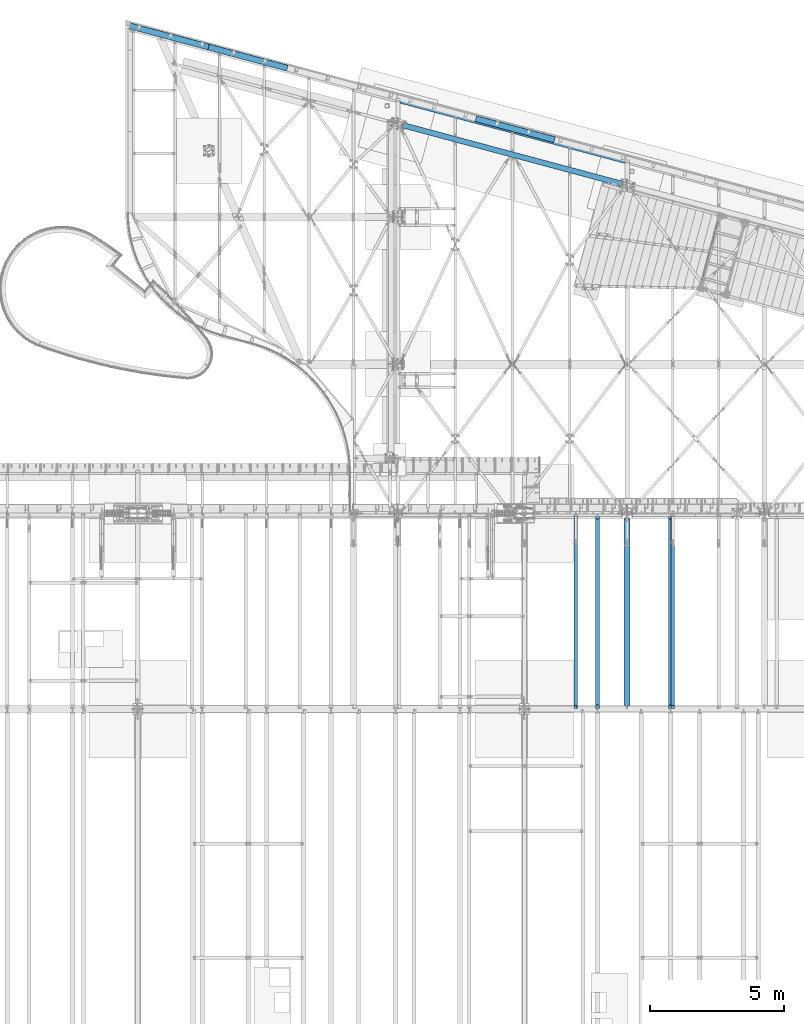
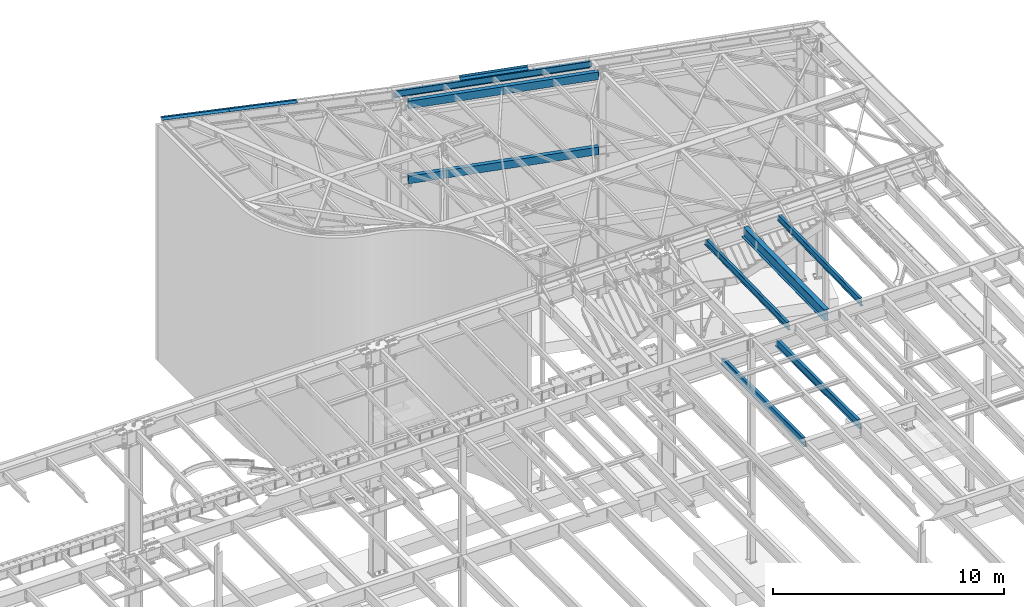
# One storey, part 1160 of 1763: 11 beams, 9 elements without a shape of their own.
"""IFC2X3 building model written with IfcOpenShell, lengths in millimetres."""

from ifc_helpers import new_model, si_unit, frame, origin_with_axes, place, context, subcontext, project, spatial, faceted_brep, material, type_object, element, aggregate, save


model = new_model("IFC2X3")

# Units and contexts
model_context = context("Model", 3, precision=1e-05, world=origin_with_axes())
body_context = subcontext(model_context, "Body", "Model", "MODEL_VIEW")
ifc_project = project(units=[si_unit("LENGTHUNIT", "METRE", prefix="MILLI"), si_unit("AREAUNIT", "SQUARE_METRE"), si_unit("VOLUMEUNIT", "CUBIC_METRE"), si_unit("MASSUNIT", "GRAM", prefix="KILO"), si_unit("TIMEUNIT", "SECOND"), si_unit("PLANEANGLEUNIT", "RADIAN"), si_unit("SOLIDANGLEUNIT", "STERADIAN"), si_unit("THERMODYNAMICTEMPERATUREUNIT", "DEGREE_CELSIUS"), si_unit("LUMINOUSINTENSITYUNIT", "LUMEN")], contexts=[model_context])

# Site, building, storey
site_placement = place(None, origin_with_axes())
site = spatial("IfcSite", under=ifc_project, at=site_placement, CompositionType="ELEMENT")
building_placement = place(site_placement, origin_with_axes())
building = spatial("IfcBuilding", under=site, at=building_placement, Name="Undefined", CompositionType="ELEMENT")
storey_placement = place(building_placement, origin_with_axes())
storey = spatial("IfcBuildingStorey", under=building, at=storey_placement, Name="Undefined", CompositionType="ELEMENT", Elevation=0.0)

# Assembly, beam
assembly_1_placement = place(storey_placement, origin_with_axes())
assembly_1 = element("IfcElementAssembly", 1, at=assembly_1_placement, inside=storey, Name="BEAM", AssemblyPlace="NOTDEFINED", PredefinedType="RIGID_FRAME")
ifc_material_1 = material()
beam_type_1 = type_object("IfcBeamType", Name="HSS16X8X5/8", PredefinedType="NOTDEFINED")
beam_1_placement = place(assembly_1_placement, frame((-39672.2896174488, 66681.4025701184, 8280.4), z_axis=(0.0, 0.0, 1.0), x_axis=(0.965925826295336, -0.25881904507913, 0.0)))
beam_1 = element("IfcBeam", 2, at=beam_1_placement, type_object=beam_type_1, material=ifc_material_1, Name="BEAM", ObjectType="HSS16X8X5/8", context=body_context, shape_type="Brep", body=[
    faceted_brep([(174.629929660281, 101.600000000712, 203.2), (174.629929640418, 101.600000000726, -203.2), (158.754929640003, 85.7250000006388, -187.325), (158.754929640003, 85.7250000006388, 187.325), (174.629929639552, -101.599999999729, -203.2), (158.754929640003, -85.7249999997366, -187.325), (174.629929646464, -101.600000007791, 203.200000005744), (158.754929640003, -85.7249999997366, 187.325), (8704.59949159464, -85.7249999754858, -187.325), (8688.72449160701, -101.599999975559, -203.2), (8688.7244915844, 101.600000024882, -203.2), (8704.59949159464, 85.7250000248896, -187.325), (8704.59949160298, -85.7249999917767, 187.324999992047), (8688.72449157427, -101.599999975573, 203.2), (8704.59949159464, 85.7250000248896, 187.325), (8688.72449157427, 101.600000024882, 203.2)], [[[0, 1, 2, 3]], [[4, 5, 2, 1]], [[6, 7, 5, 4]], [[8, 9, 10, 11]], [[12, 13, 9, 8]], [[14, 15, 13, 12]], [[13, 15, 0, 6]], [[9, 13, 6, 4]], [[10, 9, 4, 1]], [[15, 10, 1, 0]], [[14, 11, 10, 15]], [[11, 14, 3, 2]], [[8, 11, 2, 5]], [[12, 8, 5, 7]], [[14, 12, 7, 3]], [[0, 3, 7, 6]]]),
])
aggregate(assembly_1, [beam_1])

assembly_2_placement = place(storey_placement, origin_with_axes())
assembly_2 = element("IfcElementAssembly", 3, at=assembly_2_placement, inside=storey, Name="BEAM", AssemblyPlace="NOTDEFINED", PredefinedType="RIGID_FRAME")
beam_2_placement = place(assembly_2_placement, frame((-39672.2896174487, 66681.4025701184, 12242.8), z_axis=(0.0, 0.0, 1.0), x_axis=(0.965925826295336, -0.25881904507913, 0.0)))
beam_2 = element("IfcBeam", 4, at=beam_2_placement, type_object=beam_type_1, material=ifc_material_1, Name="BEAM", ObjectType="HSS16X8X5/8", context=body_context, shape_type="Brep", body=[
    faceted_brep([(174.629929660281, 101.600000000712, 203.2), (174.629929640418, 101.600000000726, -203.2), (158.754929640003, 85.7250000006388, -187.325), (158.754929640003, 85.7250000006388, 187.325), (174.629929639552, -101.599999999729, -203.2), (158.754929640003, -85.7249999997366, -187.325), (174.629929646464, -101.600000007791, 203.200000005744), (158.754929640003, -85.7249999997366, 187.325), (8704.71665785171, -85.7249999754931, -187.325000000001), (8688.84165768397, -101.59999997558, -203.200000000001), (8688.84165766144, 101.600000024868, -203.200000000001), (8704.71665785171, 85.7250000248823, -187.325000000001), (8704.71665774003, -85.7249999317428, 187.324999932076), (8688.84165783197, -101.59999997558, 203.200000000001), (8704.71665785171, 85.7250000248823, 187.325000000001), (8688.84165783197, 101.600000024868, 203.200000000001)], [[[0, 1, 2, 3]], [[4, 5, 2, 1]], [[6, 7, 5, 4]], [[8, 9, 10, 11]], [[12, 13, 9, 8]], [[14, 15, 13, 12]], [[13, 15, 0, 6]], [[9, 13, 6, 4]], [[10, 9, 4, 1]], [[15, 10, 1, 0]], [[14, 11, 10, 15]], [[11, 14, 3, 2]], [[8, 11, 2, 5]], [[12, 8, 5, 7]], [[14, 12, 7, 3]], [[0, 3, 7, 6]]]),
])
aggregate(assembly_2, [beam_2])

# Assembly, beams
assembly_3_placement = place(storey_placement, origin_with_axes())
assembly_3 = element("IfcElementAssembly", 5, at=assembly_3_placement, inside=storey, Name="BEAM", AssemblyPlace="NOTDEFINED", PredefinedType="RIGID_FRAME")
ifc_material_2 = material(Name="STEEL/A36")
beam_type_2 = type_object("IfcBeamType", PredefinedType="NOTDEFINED")
beam_3_placement = place(assembly_3_placement, frame((-48255.4900932477, 69842.5533379744, 12710.7144148035), z_axis=(-0.965507252027915, 0.25870688944179, 0.0294362300041612), x_axis=(0.258819045079128, 0.965925826295336, 0.0)))
beam_3 = element("IfcBeam", 6, at=beam_3_placement, type_object=beam_type_2, material=ifc_material_2, Name="BENT_PLATE", context=body_context, shape_type="Brep", body=[
    faceted_brep([(0.0, -3.17499999999927, -1523.99999999999), (0.0, -3.17499999999927, 1524.0), (0.0, 3.17499999999927, 1524.0), (0.0, 3.17499999999927, -1523.99999999999), (228.599995165183, 3.17499993969795, 1523.99999998704), (228.599994834185, 3.17499994154787, -1524.00000000063), (222.249995293445, -3.17500005680085, -1524.00000000046), (222.249995624443, -3.17500005865077, 1523.99999998722), (228.600000545521, -73.0249989343301, 1523.99999998058), (228.600000477083, -73.0249986697763, -1524.00000000709), (222.250000545486, -73.0249993936013, 1523.99999998076), (222.250000477034, -73.0249991290493, -1524.0000000069)], [[[0, 1, 2, 3]], [[3, 2, 4, 5]], [[1, 0, 6, 7]], [[5, 4, 8, 9]], [[4, 2, 1, 7, 10, 8]], [[7, 6, 11, 10]], [[6, 0, 3, 5, 9, 11]], [[10, 11, 9, 8]]]),
])
beam_4_placement = place(assembly_3_placement, frame((-45312.6239887956, 69054.0147402431, 12620.9927843504), z_axis=(-0.965507252027915, 0.25870688944179, 0.0294362300041612), x_axis=(0.258819045079128, 0.965925826295336, 0.0)))
beam_4 = element("IfcBeam", 7, at=beam_4_placement, type_object=beam_type_2, material=ifc_material_2, Name="BENT_PLATE", context=body_context, shape_type="Brep", body=[
    faceted_brep([(0.0, -3.17499999999927, -1523.99999999999), (0.0, -3.17499999999927, 1524.0), (0.0, 3.17499999999927, 1524.0), (0.0, 3.17499999999927, -1523.99999999999), (228.599995165183, 3.17499993969795, 1523.99999998704), (228.599994834185, 3.17499994154787, -1524.00000000063), (222.249995293445, -3.17500005680085, -1524.00000000046), (222.249995624443, -3.17500005865077, 1523.99999998722), (228.600000545521, -73.0249989343301, 1523.99999998058), (228.600000477083, -73.0249986697763, -1524.00000000709), (222.250000545486, -73.0249993936013, 1523.99999998076), (222.250000477034, -73.0249991290493, -1524.0000000069)], [[[0, 1, 2, 3]], [[3, 2, 4, 5]], [[1, 0, 6, 7]], [[5, 4, 8, 9]], [[4, 2, 1, 7, 10, 8]], [[7, 6, 11, 10]], [[6, 0, 3, 5, 9, 11]], [[10, 11, 9, 8]]]),
])
aggregate(assembly_3, [beam_3, beam_4])

# Assembly, beam
assembly_4_placement = place(storey_placement, origin_with_axes())
assembly_4 = element("IfcElementAssembly", 8, at=assembly_4_placement, inside=storey, Name="BEAM", AssemblyPlace="NOTDEFINED", PredefinedType="RIGID_FRAME")
ifc_material_3 = material(Name="STEEL/A992")
beam_type_3 = type_object("IfcBeamType", Name="W14X22", PredefinedType="NOTDEFINED")
beam_5_placement = place(assembly_4_placement, frame((-39677.0521174484, 67543.9678106676, 12271.375), z_axis=(0.0, 0.0, 1.0), x_axis=(0.965925826295336, -0.25881904507913, 0.0)))
beam_5 = element("IfcBeam", 9, at=beam_5_placement, type_object=beam_type_3, material=ifc_material_3, Name="BEAM", ObjectType="W14X22", context=body_context, shape_type="Brep", body=[
    faceted_brep([(8785.09744253859, -63.4999999752108, 174.625), (8785.09744253859, -63.4999999752108, 166.6875), (8768.93340750672, -3.17499997511914, 166.6875), (8768.93340750672, -3.17499997511914, 152.399999844461), (8767.23193013496, 3.17500002488669, 152.399999844461), (8767.23193013496, 3.17500002488669, 166.6875), (8751.06789510309, 63.5000000249784, 166.6875), (8751.06789510309, 63.5000000249784, 174.625), (8769.93423996848, -3.17499997511186, 147.539920326411), (8768.23276259669, 3.17500002489396, 147.539920326411), (8772.78436968398, -3.17499997511186, 143.419743858254), (8771.0828923122, 3.17500002489396, 143.419743858254), (8777.04989024053, -3.17499997509003, 140.666729957778), (8775.34841286876, 3.17500002491579, 140.666729957778), (8782.08141480046, -3.17499997508276, 139.700000035196), (8780.37993742868, 3.17500002493034, 139.700000035196), (8852.69398206195, -3.17499997487903, 139.700000035311), (8852.69398206194, 3.17500002513407, 139.700000035315), (113.981326006629, -63.4999999998181, 174.625), (79.9517785711287, 63.5000000003711, 174.625), (79.9517785711287, 63.5000000003711, 166.6875), (96.1158136029917, 3.17500000028667, 166.6875), (96.1158136029917, 3.17500000028667, 150.812499809434), (97.8172909747736, -3.17499999971915, 150.812499809434), (97.8172909747736, -3.17499999971915, 166.6875), (113.981326006629, -63.4999999998181, 166.6875), (95.1149811412397, 3.1750000002794, 145.952420291384), (96.8164585130216, -3.17499999972642, 145.952420291384), (92.2648514257526, 3.17500000026484, 141.832243823226), (93.96632879752, -3.17499999974098, 141.832243823226), (87.9993308691919, 3.17500000025029, 139.079229922751), (89.7008082409666, -3.17499999975553, 139.079229922751), (82.9678063092651, 3.17500000023574, 138.112500000168), (84.6692836810398, -3.17499999977008, 138.112500000168), (23.0380015252667, 3.17500000006839, 138.112500000267), (23.0380015252958, -3.1749999999447, 138.11250000027), (5.17248912165087, 63.5000000001601, -166.6875), (5.17248912165087, 63.5000000001601, -174.625), (21.3365241535139, 3.17500000007567, -174.625), (21.3365241535139, 3.17500000006112, -166.6875), (8751.06789520969, 63.5000000249784, -166.6875), (8751.06789520969, 63.5000000249784, -174.625), (39.2020365571589, -63.5000000000291, -174.625), (23.0380015252886, -3.17499999993015, -174.625), (23.0380015252667, 3.17500000008295, -174.625), (8785.09744264519, -63.4999999752035, -174.625), (39.2020365571589, -63.5000000000291, -166.6875), (8785.09744264519, -63.4999999752035, -166.6875), (23.0380015252958, -3.1749999999447, -166.6875), (8768.93340761332, -3.17499997511914, -166.6875), (23.0380015252667, 3.17500000006839, -166.6875), (8767.23193024155, 3.17500002488669, -166.6875), (8767.23193024155, 3.17500002488669, -155.574999789502), (8768.93340761332, -3.17499997511914, -155.574999789502), (8768.23276270329, 3.17500002488669, -150.714920271452), (8769.93424007506, -3.17499997511914, -150.714920271452), (8771.0828924188, 3.17500002490124, -146.594743803294), (8772.78436979057, -3.17499997510458, -146.594743803294), (8775.34841297536, 3.17500002490851, -143.841729902819), (8777.04989034712, -3.17499997509731, -143.841729902819), (8780.37993753528, 3.17500002493034, -142.874999980237), (8782.08141490705, -3.17499997508276, -142.874999980237), (8852.69398206195, -3.17499997487903, -142.874999980353), (8852.69398206194, 3.17500002513407, -142.874999980357)], [[[0, 1, 2, 3, 4, 5, 6, 7]], [[8, 9, 4, 3]], [[10, 11, 9, 8]], [[12, 13, 11, 10]], [[14, 15, 13, 12]], [[16, 17, 15, 14]], [[18, 19, 20, 21, 22, 23, 24, 25]], [[23, 22, 26, 27]], [[27, 26, 28, 29]], [[29, 28, 30, 31]], [[31, 30, 32, 33]], [[33, 32, 34, 35]], [[36, 37, 38, 39]], [[37, 36, 40, 41]], [[42, 43, 44, 38, 37, 41, 45]], [[46, 42, 45, 47]], [[48, 46, 47, 49]], [[42, 46, 48, 43]], [[35, 34, 50, 44, 43, 48]], [[39, 38, 44, 50]], [[36, 39, 50, 51, 40]], [[47, 45, 41, 40, 51, 52, 53, 49]], [[53, 52, 54, 55]], [[55, 54, 56, 57]], [[57, 56, 58, 59]], [[59, 58, 60, 61]], [[62, 61, 60, 63]], [[12, 10, 8, 3, 2, 24, 23, 27, 29, 31, 33, 35, 48, 49, 53, 55, 57, 59, 61, 62, 16, 14]], [[25, 24, 2, 1]], [[18, 25, 1, 0]], [[19, 18, 0, 7]], [[20, 19, 7, 6]], [[21, 20, 6, 5]], [[63, 60, 58, 56, 54, 52, 51, 50, 34, 32, 30, 28, 26, 22, 21, 5, 4, 9, 11, 13, 15, 17]], [[62, 63, 17, 16]]]),
])

assembly_5_placement = place(storey_placement, origin_with_axes())
assembly_5 = element("IfcElementAssembly", 10, at=assembly_5_placement, inside=storey, Name="BEAM", AssemblyPlace="NOTDEFINED", PredefinedType="RIGID_FRAME")
beam_6_placement = place(assembly_5_placement, frame((-29398.4096174484, 44809.2121579122, 11421.5633921212), z_axis=(0.0, -0.0206852279954837, 0.999786037781472), x_axis=(0.0, 0.999786037781472, 0.0206852279954825)))
beam_6 = element("IfcBeam", 11, at=beam_6_placement, type_object=beam_type_3, material=ifc_material_3, Name="BEAM", ObjectType="W14X22", context=body_context, shape_type="Brep", body=[
    faceted_brep([(116.24722620719, -3.17499999999927, 136.265001678286), (116.24722620719, 3.17499999999927, 136.265001678286), (17.4665018602245, 3.17499999999927, 136.265001678306), (17.4665018602245, -3.17499999999927, 136.265001678306), (121.10730572528, -3.17499999999927, 137.231731600872), (121.10730572528, 3.17499999999927, 137.231731600872), (125.227482193462, -3.17499999999927, 139.984745501344), (125.227482193462, 3.17499999999927, 139.984745501344), (127.980496093973, -3.17499999999927, 144.104921969487), (127.980496093973, 3.17499999999927, 144.104921969487), (128.947226016564, -3.17499999999927, 148.965001487522), (128.947226016564, 3.17499999999927, 148.965001487522), (128.947226016564, -63.5, 174.624999999836), (128.947226016564, 63.5, 174.624999999836), (128.947226016571, 63.5, 166.687499999842), (128.947226016571, 3.17499999999927, 166.687499999842), (128.947226016571, -3.17499999999927, 166.687499999842), (128.947226016571, -63.5, 166.687499999842), (11.1985191797066, -3.17499999999927, -166.687499999876), (11.1985191797066, -63.5, -166.687499999876), (7286.68019766203, -63.5, -166.687500001812), (7286.68019766203, -3.17499999999927, -166.687500001812), (11.0342950447375, -63.5, -174.624999999869), (7286.51597352705, -63.5, -174.625000001804), (11.0342950447375, 63.5, -174.624999999869), (7286.51597352705, 63.5, -174.625000001804), (11.1985191797066, 63.5, -166.687499999876), (7286.68019766203, 63.5, -166.687500001812), (11.1985191797066, 3.17499999999927, -166.687499999876), (7286.68019766203, 3.17499999999927, -166.687500001812), (7292.55404233934, 3.17499999999927, 117.214997851617), (7292.55404233934, -3.17499999999927, 117.214997851617), (7175.8289043449, 3.17499999999927, 117.214997851641), (7175.8289043449, -3.17499999999927, 117.214997851641), (7170.96882482681, 3.17499999999927, 118.181727774227), (7170.96882482681, -3.17499999999927, 118.181727774227), (7166.84864835862, 3.17499999999927, 120.9347416747), (7166.84864835862, -3.17499999999927, 120.9347416747), (7164.09563445811, 3.17499999999927, 125.054918142847), (7164.09563445811, -3.17499999999927, 125.054918142847), (7163.12890453552, 3.17499999999927, 129.914997660881), (7163.12890453552, -3.17499999999927, 129.914997660881), (7163.12890453552, -63.5, 174.624999997965), (7163.12890453552, -63.5, 166.687499997972), (7163.12890453552, -3.17499999999927, 166.687499997972), (7163.12890453552, 3.17499999999927, 166.687499997972), (7163.12890453552, 63.5, 166.687499997972), (7163.12890453552, 63.5, 174.624999997965)], [[[0, 1, 2, 3]], [[4, 5, 1, 0]], [[6, 7, 5, 4]], [[8, 9, 7, 6]], [[10, 11, 9, 8]], [[12, 13, 14, 15, 11, 10, 16, 17]], [[18, 19, 20, 21]], [[19, 22, 23, 20]], [[22, 24, 25, 23]], [[24, 26, 27, 25]], [[26, 28, 29, 27]], [[21, 20, 23, 25, 27, 29, 30, 31]], [[31, 30, 32, 33]], [[33, 32, 34, 35]], [[35, 34, 36, 37]], [[37, 36, 38, 39]], [[39, 38, 40, 41]], [[42, 43, 44, 41, 40, 45, 46, 47]], [[43, 42, 12, 17]], [[44, 43, 17, 16]], [[8, 6, 4, 0, 3, 18, 21, 31, 33, 35, 37, 39, 41, 44, 16, 10]], [[28, 26, 24, 22, 19, 18, 3, 2]], [[45, 40, 38, 36, 34, 32, 30, 29, 28, 2, 1, 5, 7, 9, 11, 15]], [[46, 45, 15, 14]], [[47, 46, 14, 13]], [[42, 47, 13, 12]]]),
])
aggregate(assembly_5, [beam_6])

assembly_6_placement = place(storey_placement, origin_with_axes())
assembly_6 = element("IfcElementAssembly", 12, at=assembly_6_placement, inside=storey, Name="BEAM", AssemblyPlace="NOTDEFINED", PredefinedType="RIGID_FRAME")
beam_7_placement = place(assembly_6_placement, frame((-33032.1372736984, 44809.2121579121, 11421.5633921212), z_axis=(0.0, -0.0206852279954837, 0.999786037781472), x_axis=(0.0, 0.999786037781472, 0.0206852279954825)))
beam_7 = element("IfcBeam", 13, at=beam_7_placement, type_object=beam_type_3, material=ifc_material_3, Name="BEAM", ObjectType="W14X22", context=body_context, shape_type="Brep", body=[
    faceted_brep([(116.24722620719, -3.17499999999927, 136.265001678286), (116.24722620719, 3.17499999999927, 136.265001678286), (17.4665018602245, 3.17499999999927, 136.265001678306), (17.4665018602245, -3.17499999999927, 136.265001678306), (121.10730572528, -3.17499999999927, 137.231731600872), (121.10730572528, 3.17499999999927, 137.231731600872), (125.227482193462, -3.17499999999927, 139.984745501344), (125.227482193462, 3.17499999999927, 139.984745501344), (127.980496093973, -3.17499999999927, 144.104921969487), (127.980496093973, 3.17499999999927, 144.104921969487), (128.947226016564, -3.17499999999927, 148.965001487522), (128.947226016564, 3.17499999999927, 148.965001487522), (128.947226016564, -63.5, 174.624999999836), (128.947226016564, 63.5, 174.624999999836), (128.947226016571, 63.5, 166.687499999842), (128.947226016571, 3.17499999999927, 166.687499999842), (128.947226016571, -3.17499999999927, 166.687499999842), (128.947226016571, -63.5, 166.687499999842), (11.1985191797066, -3.17499999999927, -166.687499999876), (11.1985191797066, -63.5, -166.687499999876), (7286.68019766203, -63.5, -166.687500001812), (7286.68019766203, -3.17499999999927, -166.687500001812), (11.0342950447375, -63.5, -174.624999999869), (7286.51597352705, -63.5, -174.625000001804), (11.0342950447375, 63.5, -174.624999999869), (7286.51597352705, 63.5, -174.625000001804), (11.1985191797066, 63.5, -166.687499999876), (7286.68019766203, 63.5, -166.687500001812), (11.1985191797066, 3.17499999999927, -166.687499999876), (7286.68019766203, 3.17499999999927, -166.687500001812), (7292.02852510755, 3.17499999999927, 91.8149978515976), (7292.02852510755, -3.17499999999927, 91.8149978515976), (7125.028904344, 3.17499999999927, 91.8149978516285), (7125.028904344, -3.17499999999927, 91.8149978516285), (7120.16882482591, 3.17499999999927, 92.7817277742161), (7120.16882482591, -3.17499999999927, 92.7817277742161), (7116.04864835773, 3.17499999999927, 95.5347416746881), (7116.04864835773, -3.17499999999927, 95.5347416746881), (7113.29563445722, 3.17499999999927, 99.6549181428345), (7113.29563445722, -3.17499999999927, 99.6549181428345), (7112.32890453462, 3.17499999999927, 104.51499766087), (7112.32890453462, -3.17499999999927, 104.51499766087), (7112.32890453463, -63.5, 174.624999997979), (7112.32890453462, -63.5, 166.687499997985), (7112.32890453462, -3.17499999999927, 166.687499997985), (7112.32890453462, 3.17499999999927, 166.687499997985), (7112.32890453462, 63.5, 166.687499997985), (7112.32890453463, 63.5, 174.624999997979)], [[[0, 1, 2, 3]], [[4, 5, 1, 0]], [[6, 7, 5, 4]], [[8, 9, 7, 6]], [[10, 11, 9, 8]], [[12, 13, 14, 15, 11, 10, 16, 17]], [[18, 19, 20, 21]], [[19, 22, 23, 20]], [[22, 24, 25, 23]], [[24, 26, 27, 25]], [[26, 28, 29, 27]], [[21, 20, 23, 25, 27, 29, 30, 31]], [[31, 30, 32, 33]], [[33, 32, 34, 35]], [[35, 34, 36, 37]], [[37, 36, 38, 39]], [[39, 38, 40, 41]], [[42, 43, 44, 41, 40, 45, 46, 47]], [[43, 42, 12, 17]], [[44, 43, 17, 16]], [[8, 6, 4, 0, 3, 18, 21, 31, 33, 35, 37, 39, 41, 44, 16, 10]], [[28, 26, 24, 22, 19, 18, 3, 2]], [[45, 40, 38, 36, 34, 32, 30, 29, 28, 2, 1, 5, 7, 9, 11, 15]], [[46, 45, 15, 14]], [[47, 46, 14, 13]], [[42, 47, 13, 12]]]),
])
aggregate(assembly_6, [beam_7])

# Beam
beam_type_4 = type_object("IfcBeamType", PredefinedType="NOTDEFINED")
beam_8_placement = place(assembly_4_placement, frame((-35323.3129177373, 66377.3869081666, 12449.175), z_axis=(-0.965925827679309, 0.258819039914073, 0.0), x_axis=(0.258819045079128, 0.965925826295336, 0.0)))
beam_8 = element("IfcBeam", 14, at=beam_8_placement, type_object=beam_type_4, material=ifc_material_2, Name="BENT_PLATE", context=body_context, shape_type="Brep", body=[
    faceted_brep([(0.0, -3.17499999999927, -1523.99999999999), (0.0, -3.17499999999927, 1524.0), (0.0, 3.17499999999927, 1524.0), (0.0, 3.17499999999927, -1523.99999999999), (228.599995165183, 3.17499993969795, 1523.99999998704), (228.599994834185, 3.17499994154787, -1524.00000000063), (222.249995293445, -3.17500005680085, -1524.00000000046), (222.249995624443, -3.17500005865077, 1523.99999998722), (228.599994977769, -123.824999999819, 1524.000000004), (228.599994986405, -123.824999999819, -1524.00000000269), (222.249994977741, -123.824999999819, 1524.00000000397), (222.249994986378, -123.824999999819, -1524.00000000271)], [[[0, 1, 2, 3]], [[3, 2, 4, 5]], [[1, 0, 6, 7]], [[5, 4, 8, 9]], [[4, 2, 1, 7, 10, 8]], [[7, 6, 11, 10]], [[6, 0, 3, 5, 9, 11]], [[10, 11, 9, 8]]]),
])

aggregate(assembly_4, [beam_8, beam_5])

# Assembly, beam
assembly_7_placement = place(storey_placement, origin_with_axes())
assembly_7 = element("IfcElementAssembly", 15, at=assembly_7_placement, inside=storey, Name="BEAM", AssemblyPlace="NOTDEFINED", PredefinedType="RIGID_FRAME")
beam_type_5 = type_object("IfcBeamType", Name="W24X76", PredefinedType="NOTDEFINED")
beam_9_placement = place(assembly_7_placement, frame((-31109.3096174484, 44811.8720196671, 11293.0034049879), z_axis=(0.0, -0.0206852279954837, 0.999786037781472), x_axis=(0.0, 0.999786037781472, 0.0206852279954825)))
beam_9 = element("IfcBeam", 16, at=beam_9_placement, type_object=beam_type_5, material=ifc_material_3, Name="BEAM", ObjectType="W24X76", context=body_context, shape_type="Brep", body=[
    faceted_brep([(6.49632960907184, -5.55625000000146, -265.372499999168), (6.49632960907184, 5.55625000000146, -265.372499999168), (113.586795220392, 5.55625000000146, -265.372499999228), (113.586795220392, -5.55625000000146, -265.372499999228), (118.446874738482, 5.55625000000146, -266.339229921816), (118.446874738482, -5.55625000000146, -266.339229921816), (122.567051206664, 5.55625000000146, -269.092243822288), (122.567051206664, -5.55625000000146, -269.092243822288), (125.32006510716, 5.55625000000146, -273.212420290434), (125.32006510716, -5.55625000000146, -273.212420290434), (126.286795029759, -5.55625000000146, -278.07249980847), (126.286795029759, 5.55625000000146, -278.07249980847), (126.286795029759, 5.55625000000146, -285.749999999816), (126.286795029759, 114.299999999999, -285.749999999816), (126.286795029751, 114.299999999999, -303.212499999803), (126.286795029751, -114.299999999999, -303.212499999803), (126.286795029759, -114.299999999999, -285.749999999816), (126.286795029759, -5.55625000000146, -285.749999999816), (126.286795029817, 5.55625000000146, 285.749999999754), (126.286795029817, 114.299999999999, 285.749999999754), (7109.66847354787, 114.299999999999, 285.749999997897), (7109.66847354787, 5.55625000000146, 285.749999997897), (113.58679522045, -5.55625000000146, 264.852501677899), (113.58679522045, 5.55625000000146, 264.852501677899), (17.4665018600936, 5.55625000000146, 264.852501677915), (17.4665018600936, -5.55625000000146, 264.852501677915), (118.446874738533, -5.55625000000146, 265.819231600481), (118.446874738533, 5.55625000000146, 265.819231600481), (122.567051206723, -5.55625000000146, 268.572245500953), (122.567051206723, 5.55625000000146, 268.572245500953), (125.320065107226, -5.55625000000146, 272.692421969095), (125.320065107226, 5.55625000000146, 272.692421969095), (126.286795029824, -5.55625000000146, 277.552501487131), (126.286795029824, 5.55625000000146, 277.552501487131), (126.286795029817, -114.299999999999, 303.212499999741), (126.286795029817, 114.299999999999, 303.212499999741), (126.286795029817, -5.55625000000146, 285.749999999754), (126.286795029817, -114.299999999999, 285.749999999754), (7109.66847354787, -5.55625000000146, 285.749999997897), (7109.66847354787, -114.299999999999, 285.749999997897), (7109.66847354788, -114.299999999999, 303.212499997884), (7109.66847354788, 114.299999999999, 303.212499997884), (7109.66847354787, -5.55625000000146, 233.102497660489), (7109.66847354787, 5.55625000000146, 233.102497660489), (7110.63520347048, -5.55625000000146, 228.242418142454), (7110.63520347048, 5.55625000000146, 228.242418142454), (7113.38821737097, -5.55625000000146, 224.122241674309), (7113.38821737097, 5.55625000000146, 224.122241674309), (7117.50839383915, -5.55625000000146, 221.369227773837), (7117.50839383915, 5.55625000000146, 221.369227773837), (7122.36847335724, -5.55625000000146, 220.402497851248), (7122.36847335724, 5.55625000000146, 220.402497851248), (7292.02852510743, -5.55625000000146, 220.402497851217), (7292.02852510743, 5.55625000000146, 220.402497851217), (7281.55640465069, -5.55625000000146, -285.750000001717), (7281.55640465069, -114.299999999999, -285.750000001717), (7281.19511155374, -114.299999999999, -303.212500001704), (7281.19511155374, 114.299999999999, -303.212500001704), (7281.55640465069, 114.299999999999, -285.750000001717), (7281.55640465069, 5.55625000000146, -285.750000001717)], [[[0, 1, 2, 3]], [[3, 2, 4, 5]], [[5, 4, 6, 7]], [[7, 6, 8, 9]], [[10, 11, 12, 13, 14, 15, 16, 17]], [[9, 8, 11, 10]], [[18, 19, 20, 21]], [[22, 23, 24, 25]], [[26, 27, 23, 22]], [[28, 29, 27, 26]], [[30, 31, 29, 28]], [[32, 33, 31, 30]], [[34, 35, 19, 18, 33, 32, 36, 37]], [[37, 36, 38, 39]], [[34, 37, 39, 40]], [[35, 34, 40, 41]], [[19, 35, 41, 20]], [[40, 39, 38, 42, 43, 21, 20, 41]], [[44, 45, 43, 42]], [[46, 47, 45, 44]], [[48, 49, 47, 46]], [[50, 51, 49, 48]], [[52, 53, 51, 50]], [[54, 55, 56, 57, 58, 59, 53, 52]], [[55, 54, 17, 16]], [[56, 55, 16, 15]], [[57, 56, 15, 14]], [[58, 57, 14, 13]], [[59, 58, 13, 12]], [[6, 4, 2, 1, 24, 23, 27, 29, 31, 33, 18, 21, 43, 45, 47, 49, 51, 53, 59, 12, 11, 8]], [[25, 24, 1, 0]], [[54, 52, 50, 48, 46, 44, 42, 38, 36, 32, 30, 28, 26, 22, 25, 0, 3, 5, 7, 9, 10, 17]]]),
])
aggregate(assembly_7, [beam_9])

assembly_8_placement = place(storey_placement, origin_with_axes())
assembly_8 = element("IfcElementAssembly", 17, at=assembly_8_placement, inside=storey, Name="BEAM", AssemblyPlace="NOTDEFINED", PredefinedType="RIGID_FRAME")
beam_type_6 = type_object("IfcBeamType", Name="W16X31", PredefinedType="NOTDEFINED")
beam_10_placement = place(assembly_8_placement, frame((-32219.3372736984, 44805.6, 4992.6875), z_axis=(0.0, 0.0, 1.0), x_axis=(0.0, 1.0, 0.0)))
beam_10 = element("IfcBeam", 18, at=beam_10_placement, type_object=beam_type_6, material=ifc_material_3, Name="BEAM", ObjectType="W16X31", context=body_context, shape_type="Brep", body=[
    faceted_brep([(133.349999433754, -3.17499999999927, 169.602501678466), (133.349999433754, 3.17499999999927, 169.602501678466), (19.0499999999956, 3.17499999999927, 169.602501678466), (19.0499999999956, -3.17499999999927, 169.602501678466), (138.210078951801, -3.17499999999927, 170.569231601054), (138.210078951801, 3.17499999999927, 170.569231601054), (142.330255419954, -3.17499999999927, 173.322245501532), (142.330255419954, 3.17499999999927, 173.322245501532), (145.083269320428, -3.17499999999927, 177.442421969686), (145.083269320428, 3.17499999999927, 177.442421969686), (146.04999924302, -3.17499999999927, 182.302501487731), (146.04999924302, 3.17499999999927, 182.302501487731), (146.04999924302, -69.8499999999985, 201.6125), (146.04999924302, 69.8499999999985, 201.6125), (146.04999924302, 69.8499999999985, 190.5), (146.04999924302, 3.17499999999927, 190.5), (146.04999924302, -3.17499999999927, 190.5), (146.04999924302, -69.8499999999985, 190.5), (19.0499999999956, -3.17499999999927, -190.5), (19.0499999999956, -69.8499999999985, -190.5), (7292.18125, -69.8499999999985, -190.5), (7292.18125, -3.17499999999927, -190.5), (19.0499999999956, -69.8499999999985, -201.6125), (7292.18125, -69.8499999999985, -201.6125), (19.0499999999956, 69.8499999999985, -201.6125), (7292.18125, 69.8499999999985, -201.6125), (19.0499999999956, 69.8499999999985, -190.5), (7292.18125, 69.8499999999985, -190.5), (19.0499999999956, 3.17499999999927, -190.5), (7292.18125, 3.17499999999927, -190.5), (7292.18125, 3.17499999999927, 144.202497863769), (7292.18125, -3.17499999999927, 144.202497863769), (7120.73124980927, 3.17499999999927, 144.202497863769), (7120.73124980927, -3.17499999999927, 144.202497863769), (7115.87117029122, 3.17499999999927, 145.169227786357), (7115.87117029122, -3.17499999999927, 145.169227786357), (7111.75099382307, 3.17499999999927, 147.922241686835), (7111.75099382307, -3.17499999999927, 147.922241686835), (7108.99797992258, 3.17499999999927, 152.042418154989), (7108.99797992258, -3.17499999999927, 152.042418154989), (7108.03125, 3.17499999999927, 156.902497673034), (7108.03125, -3.17499999999927, 156.902497673034), (7108.03125, -69.8499999999985, 201.6125), (7108.03125, -69.8499999999985, 190.5), (7108.03125, -3.17499999999927, 190.5), (7108.03125, 3.17499999999927, 190.5), (7108.03125, 69.8499999999985, 190.5), (7108.03125, 69.8499999999985, 201.6125)], [[[0, 1, 2, 3]], [[4, 5, 1, 0]], [[6, 7, 5, 4]], [[8, 9, 7, 6]], [[10, 11, 9, 8]], [[12, 13, 14, 15, 11, 10, 16, 17]], [[18, 19, 20, 21]], [[19, 22, 23, 20]], [[22, 24, 25, 23]], [[24, 26, 27, 25]], [[26, 28, 29, 27]], [[21, 20, 23, 25, 27, 29, 30, 31]], [[31, 30, 32, 33]], [[33, 32, 34, 35]], [[35, 34, 36, 37]], [[37, 36, 38, 39]], [[39, 38, 40, 41]], [[42, 43, 44, 41, 40, 45, 46, 47]], [[43, 42, 12, 17]], [[44, 43, 17, 16]], [[8, 6, 4, 0, 3, 18, 21, 31, 33, 35, 37, 39, 41, 44, 16, 10]], [[28, 26, 24, 22, 19, 18, 3, 2]], [[45, 40, 38, 36, 34, 32, 30, 29, 28, 2, 1, 5, 7, 9, 11, 15]], [[46, 45, 15, 14]], [[47, 46, 14, 13]], [[42, 47, 13, 12]]]),
])
aggregate(assembly_8, [beam_10])

assembly_9_placement = place(storey_placement, origin_with_axes())
assembly_9 = element("IfcElementAssembly", 19, at=assembly_9_placement, inside=storey, Name="BEAM", AssemblyPlace="NOTDEFINED", PredefinedType="RIGID_FRAME")
beam_11_placement = place(assembly_9_placement, frame((-29488.8372736984, 44805.6, 4992.6875), z_axis=(0.0, 0.0, 1.0), x_axis=(0.0, 1.0, 0.0)))
beam_11 = element("IfcBeam", 20, at=beam_11_placement, type_object=beam_type_6, material=ifc_material_3, Name="BEAM", ObjectType="W16X31", context=body_context, shape_type="Brep", body=[
    faceted_brep([(133.349999433754, -3.17499999999927, 169.602501678466), (133.349999433754, 3.17499999999927, 169.602501678466), (19.0499999999956, 3.17499999999927, 169.602501678466), (19.0499999999956, -3.17499999999927, 169.602501678466), (138.210078951801, -3.17499999999927, 170.569231601054), (138.210078951801, 3.17499999999927, 170.569231601054), (142.330255419954, -3.17499999999927, 173.322245501532), (142.330255419954, 3.17499999999927, 173.322245501532), (145.083269320428, -3.17499999999927, 177.442421969686), (145.083269320428, 3.17499999999927, 177.442421969686), (146.04999924302, -3.17499999999927, 182.302501487731), (146.04999924302, 3.17499999999927, 182.302501487731), (146.04999924302, -69.8499999999985, 201.6125), (146.04999924302, 69.8499999999985, 201.6125), (146.04999924302, 69.8499999999985, 190.5), (146.04999924302, 3.17499999999927, 190.5), (146.04999924302, -3.17499999999927, 190.5), (146.04999924302, -69.8499999999985, 190.5), (19.0499999999956, -3.17499999999927, -190.5), (19.0499999999956, -69.8499999999985, -190.5), (7292.18125, -69.8499999999985, -190.5), (7292.18125, -3.17499999999927, -190.5), (19.0499999999956, -69.8499999999985, -201.6125), (7292.18125, -69.8499999999985, -201.6125), (19.0499999999956, 69.8499999999985, -201.6125), (7292.18125, 69.8499999999985, -201.6125), (19.0499999999956, 69.8499999999985, -190.5), (7292.18125, 69.8499999999985, -190.5), (19.0499999999956, 3.17499999999927, -190.5), (7292.18125, 3.17499999999927, -190.5), (7292.18125, 3.17499999999927, 144.202497863769), (7292.18125, -3.17499999999927, 144.202497863769), (7120.73124980927, 3.17499999999927, 144.202497863769), (7120.73124980927, -3.17499999999927, 144.202497863769), (7115.87117029122, 3.17499999999927, 145.169227786357), (7115.87117029122, -3.17499999999927, 145.169227786357), (7111.75099382307, 3.17499999999927, 147.922241686835), (7111.75099382307, -3.17499999999927, 147.922241686835), (7108.99797992258, 3.17499999999927, 152.042418154989), (7108.99797992258, -3.17499999999927, 152.042418154989), (7108.03125, 3.17499999999927, 156.902497673034), (7108.03125, -3.17499999999927, 156.902497673034), (7108.03125, -69.8499999999985, 201.6125), (7108.03125, -69.8499999999985, 190.5), (7108.03125, -3.17499999999927, 190.5), (7108.03125, 3.17499999999927, 190.5), (7108.03125, 69.8499999999985, 190.5), (7108.03125, 69.8499999999985, 201.6125)], [[[0, 1, 2, 3]], [[4, 5, 1, 0]], [[6, 7, 5, 4]], [[8, 9, 7, 6]], [[10, 11, 9, 8]], [[12, 13, 14, 15, 11, 10, 16, 17]], [[18, 19, 20, 21]], [[19, 22, 23, 20]], [[22, 24, 25, 23]], [[24, 26, 27, 25]], [[26, 28, 29, 27]], [[21, 20, 23, 25, 27, 29, 30, 31]], [[31, 30, 32, 33]], [[33, 32, 34, 35]], [[35, 34, 36, 37]], [[37, 36, 38, 39]], [[39, 38, 40, 41]], [[42, 43, 44, 41, 40, 45, 46, 47]], [[43, 42, 12, 17]], [[44, 43, 17, 16]], [[8, 6, 4, 0, 3, 18, 21, 31, 33, 35, 37, 39, 41, 44, 16, 10]], [[28, 26, 24, 22, 19, 18, 3, 2]], [[45, 40, 38, 36, 34, 32, 30, 29, 28, 2, 1, 5, 7, 9, 11, 15]], [[46, 45, 15, 14]], [[47, 46, 14, 13]], [[42, 47, 13, 12]]]),
])
aggregate(assembly_9, [beam_11])

save(model, "model.ifc")
